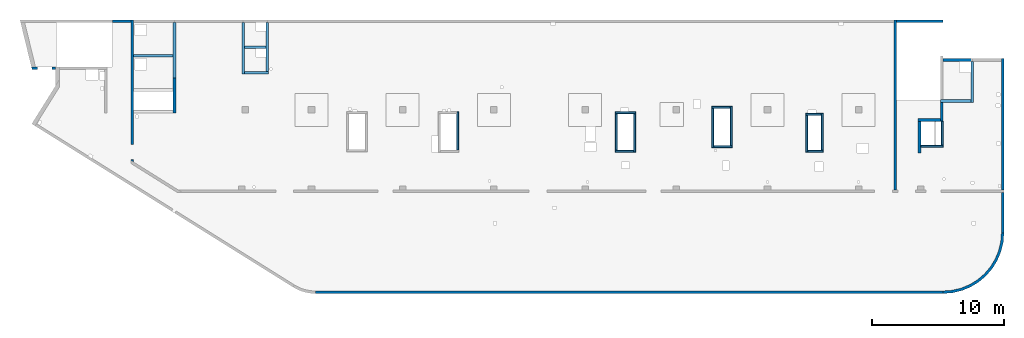
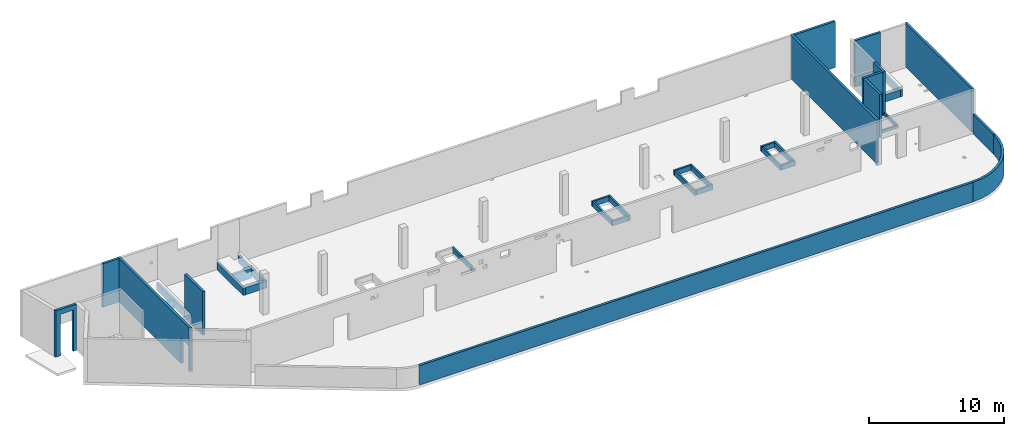
# One storey, part 3 of 6: 37 walls, 3 openings.
"""IFC4 building model written with IfcOpenShell, lengths in millimetres."""

from ifc_helpers import new_model, entity, si_unit, converted_unit, derived_unit, direction, frame, origin, place, context, subcontext, project, spatial, indexed_curve, outline, extrude, polygons, material, type_object, element, save


model = new_model("IFC4")

# Units and contexts
model_context = context("Model", 3, precision=0.01, world=origin(), true_north=direction((6.12303176911189e-17, 1.0)))
plan_context = context("Plan", 3, precision=0.01, world=origin(), true_north=direction((6.12303176911189e-17, 1.0)))
body_context = subcontext(model_context, "Body", "Model", "MODEL_VIEW")
ifc_project = project(units=[si_unit("LENGTHUNIT", "METRE", prefix="MILLI"), si_unit("AREAUNIT", "SQUARE_METRE"), si_unit("VOLUMEUNIT", "CUBIC_METRE"), converted_unit("PLANEANGLEUNIT", "DEGREE", entity("IfcRatioMeasure", 0.0174532925199433), si_unit("PLANEANGLEUNIT", "RADIAN"), dimensions=[0, 0, 0, 0, 0, 0, 0]), si_unit("MASSUNIT", "GRAM", prefix="KILO"), derived_unit("MASSDENSITYUNIT", [(si_unit("MASSUNIT", "GRAM", prefix="KILO"), 1), (si_unit("LENGTHUNIT", "METRE"), -3)]), derived_unit("MOMENTOFINERTIAUNIT", [(si_unit("LENGTHUNIT", "METRE"), 4)]), si_unit("TIMEUNIT", "SECOND"), si_unit("FREQUENCYUNIT", "HERTZ"), si_unit("THERMODYNAMICTEMPERATUREUNIT", "DEGREE_CELSIUS"), derived_unit("THERMALTRANSMITTANCEUNIT", [(si_unit("MASSUNIT", "GRAM", prefix="KILO"), 1), (si_unit("THERMODYNAMICTEMPERATUREUNIT", "KELVIN"), -1), (si_unit("TIMEUNIT", "SECOND"), -3)]), derived_unit("VOLUMETRICFLOWRATEUNIT", [(si_unit("LENGTHUNIT", "METRE"), 3), (si_unit("TIMEUNIT", "SECOND"), -1)]), derived_unit("MASSFLOWRATEUNIT", [(si_unit("MASSUNIT", "GRAM", prefix="KILO"), 1), (si_unit("TIMEUNIT", "SECOND"), -1)]), derived_unit("ROTATIONALFREQUENCYUNIT", [(si_unit("TIMEUNIT", "SECOND"), -1)]), si_unit("ELECTRICCURRENTUNIT", "AMPERE"), si_unit("ELECTRICVOLTAGEUNIT", "VOLT"), si_unit("POWERUNIT", "WATT"), si_unit("FORCEUNIT", "NEWTON", prefix="KILO"), si_unit("ILLUMINANCEUNIT", "LUX"), si_unit("LUMINOUSFLUXUNIT", "LUMEN"), si_unit("LUMINOUSINTENSITYUNIT", "CANDELA"), derived_unit("USERDEFINED", [(si_unit("MASSUNIT", "GRAM", prefix="KILO"), -1), (si_unit("LENGTHUNIT", "METRE"), -2), (si_unit("TIMEUNIT", "SECOND"), 3), (si_unit("LUMINOUSFLUXUNIT", "LUMEN"), 1)]), derived_unit("LINEARVELOCITYUNIT", [(si_unit("LENGTHUNIT", "METRE"), 1), (si_unit("TIMEUNIT", "SECOND"), -1)]), si_unit("PRESSUREUNIT", "PASCAL"), derived_unit("USERDEFINED", [(si_unit("LENGTHUNIT", "METRE"), -2), (si_unit("MASSUNIT", "GRAM", prefix="KILO"), 1), (si_unit("TIMEUNIT", "SECOND"), -2)]), derived_unit("LINEARFORCEUNIT", [(si_unit("MASSUNIT", "GRAM", prefix="KILO"), 1), (si_unit("LENGTHUNIT", "METRE"), 1), (si_unit("TIMEUNIT", "SECOND"), -2), (si_unit("LENGTHUNIT", "METRE"), -1)]), derived_unit("PLANARFORCEUNIT", [(si_unit("MASSUNIT", "GRAM", prefix="KILO"), 1), (si_unit("LENGTHUNIT", "METRE"), 1), (si_unit("TIMEUNIT", "SECOND"), -2), (si_unit("LENGTHUNIT", "METRE"), -2)])], contexts=[model_context, plan_context])

# Site, building, storey
site_placement = place(None, origin())
site = spatial("IfcSite", under=ifc_project, at=site_placement, CompositionType="ELEMENT")
building_placement = place(site_placement, origin())
building = spatial("IfcBuilding", under=site, at=building_placement, CompositionType="ELEMENT")
storey_placement = place(building_placement, frame((0.0, 0.0, 28200.0)))
storey = spatial("IfcBuildingStorey", under=building, at=storey_placement, Name="08", CompositionType="ELEMENT", Elevation=28200.0)

# Wall, opening
ifc_material = material()
wall_type_1 = type_object("IfcWallType", Name=":ADSK_ 25_200", PredefinedType="STANDARD")
wall_1_placement = place(storey_placement, frame((1805.0, 16860.0, -400.0), z_axis=(0.0, 0.0, 1.0), x_axis=(-1.0, 0.0, 0.0)))
wall_1 = element("IfcWall", 1, at=wall_1_placement, inside=storey, type_object=wall_type_1, material=ifc_material, Name=":ADSK_ 25_200", ObjectType=":ADSK_ 25_200", PredefinedType="NOTDEFINED", context=body_context, shape_type="Tessellation", body=[
    polygons([(1834.46650967482, -100.000000000001, 4200.0), (1525.68223251125, -100.000000000001, 4200.0), (2.33197173806285e-13, -100.000000000001, 4200.0), (2.33197173806285e-13, -100.000000000001, 249.999999999999), (2.33197173806285e-13, -100.000000000001, 0.0), (275.0, -100.000000000001, 0.0), (275.0, -100.000000000322, 3750.0), (1375.0, -100.000000000324, 3750.0), (1375.0, -100.000000000003, 0.0), (1525.68223251125, -100.000000000001, 0.0), (1834.46650967482, -100.000000000001, 0.0), (-6.38934712472434e-14, 100.000000000001, 4200.0), (1785.71439371649, 99.9999999999989, 4200.0), (1785.71439371649, 99.9999999999989, 0.0), (1375.0, 99.9999999999968, 0.0), (1375.0, 99.9999999999968, 3750.00000000001), (275.0, 100.000000000001, 3750.00000000001), (275.0, 100.000000000001, 0.0), (-6.38934712472434e-14, 100.000000000001, 0.0)], [[[1, 2, 3, 4, 5, 6, 7, 8, 9, 10, 11]], [[12, 13, 14, 15, 16, 17, 18, 19]], [[5, 19, 18, 6]], [[3, 2, 1, 13, 12]], [[5, 4, 3, 12, 19]], [[1, 11, 14, 13]], [[16, 8, 7, 17]], [[8, 16, 15, 9]], [[17, 7, 6, 18]], [[14, 11, 10, 9, 15]]], closed=True),
])
opening_1_placement = place(wall_1_placement, frame((1805.0, 16860.0, 400.0), z_axis=(0.0, 0.0, 1.0), x_axis=(-1.0, 0.0, 0.0)))
element("IfcOpeningElement", 2, at=opening_1_placement, cuts=wall_1, Name=":ADSK_ 25_200", PredefinedType="OPENING", context=body_context, shape_type="SweptSolid", body=[
    extrude(outline(indexed_curve([(-550.0, -3149.99999999999), (550.0, -3149.99999999999), (550.0, 3149.99999999999), (-550.0, 3149.99999999999), (-550.0, -3149.99999999999)], self_intersect=False)), frame((980.0, 16960.0, 200.0), z_axis=(0.0, -1.0, 0.0), x_axis=(-1.0, 0.0, 0.0)), (0.0, 0.0, 1.0), 200.000000000962),
])

wall_2_placement = place(storey_placement, frame((7600.0, 20500.0, -150.0), z_axis=(0.0, 0.0, 1.0), x_axis=(0.0, -1.0, 0.0)))
wall_2 = element("IfcWall", 3, at=wall_2_placement, inside=storey, type_object=wall_type_1, material=ifc_material, Name=":ADSK_ 25_200", ObjectType=":ADSK_ 25_200", PredefinedType="NOTDEFINED", context=body_context, shape_type="Tessellation", body=[
    polygons([(10624.9984109254, -99.9999999999999, 3950.0), (1979.99999999983, -100.0, 3950.0), (1019.99999999983, -99.9999999999994, 3950.0), (200.000000000037, -99.9999999999996, 3950.0), (0.0, -100.000000000001, 3950.0), (0.0, -100.000000000001, 0.0), (200.000000000037, -99.9999999999996, 0.0), (9420.00063936629, -99.9999999999996, 0.0), (9420.00063936629, -99.9999999999996, 2279.99999999804), (10550.0006393663, -99.999999999999, 2279.99999999804), (10550.0006393663, -100.0, 0.0), (10624.9984109254, -99.9999999999999, 0.0), (0.0, 100.0, 3950.0), (199.999999999998, 100.0, 3950.0), (10749.9698423134, 100.0, 3950.0), (10749.9698423134, 100.0, 0.0), (10550.0006393663, 100.0, 0.0), (10550.0006393663, 100.0, 2279.99999999804), (9420.0006393663, 100.0, 2279.99999999804), (9420.00063936629, 100.0, 0.0), (7050.00063936683, 100.0, 0.0), (6850.00063936683, 100.000000000001, 0.0), (6800.00000000003, 100.000000000001, 0.0), (5400.00000000003, 100.000000000001, 0.0), (5200.00000000003, 100.0, 0.0), (0.0, 100.0, 0.0)], [[[1, 2, 3, 4, 5, 6, 7, 8, 9, 10, 11, 12]], [[13, 14, 15, 16, 17, 18, 19, 20, 21, 22, 23, 24, 25, 26]], [[6, 26, 25, 24, 23, 22, 21, 20, 8, 7]], [[5, 4, 3, 2, 1, 15, 14, 13]], [[1, 12, 16, 15]], [[6, 5, 13, 26]], [[9, 19, 18, 10]], [[10, 18, 17, 11]], [[19, 9, 8, 20]], [[16, 12, 11, 17]]], closed=True),
])
opening_2_placement = place(wall_2_placement, frame((20500.0, -7600.0, 150.0), z_axis=(0.0, 0.0, 1.0), x_axis=(0.0, 1.0, 0.0)))
element("IfcOpeningElement", 4, at=opening_2_placement, cuts=wall_2, Name=":ADSK_ 25_200", PredefinedType="OPENING", context=body_context, shape_type="SweptSolid", body=[
    extrude(outline(indexed_curve([(-564.999999999999, -1139.99999999902), (564.999999999999, -1139.99999999902), (564.999999999999, 1139.99999999902), (-564.999999999999, 1139.99999999902), (-564.999999999999, -1139.99999999902)], self_intersect=False)), frame((7400.0, 10515.0, 990.0), z_axis=(1.0, 0.0, 0.0), x_axis=(0.0, -1.0, 0.0)), (0.0, 0.0, 1.0), 400.000000001943),
])

# Walls
wall_3_placement = place(storey_placement, frame((21464.84, -100.0, -150.0)))
element("IfcWall", 5, at=wall_3_placement, inside=storey, type_object=wall_type_1, material=ifc_material, Name=":ADSK_ 25_200", ObjectType=":ADSK_ 25_200", PredefinedType="NOTDEFINED", context=body_context, shape_type="SweptSolid", body=[
    extrude(outline(indexed_curve([(47505.1554967537, 100.0), (-3.23209822019764e-13, 100.0), (3.23209822019764e-13, -100.0), (47505.1554967537, -100.0), (47505.1554967537, 100.0)], self_intersect=False)), origin(), (0.0, 0.0, 1.0), 1770.0),
])
wall_4_placement = place(storey_placement, frame((68970.0, -100.0, -150.0)))
element("IfcWall", 6, at=wall_4_placement, inside=storey, type_object=wall_type_1, material=ifc_material, Name=":ADSK_ 25_200", ObjectType=":ADSK_ 25_200", PredefinedType="NOTDEFINED", context=body_context, shape_type="SweptSolid", body=[
    extrude(outline(indexed_curve([(4399.99918212903, 4499.99918212888), (4345.82789081698, 3811.68766389508), (4184.64789385715, 3140.32465961517), (3920.42797770043, 2502.44135458057), (3559.67411357824, 1913.74455277455), (3111.26925889869, 1388.72992323025), (2586.25462935438, 940.325068550714), (1997.55782754836, 579.571204428536), (1359.67452251375, 315.35128827184), (688.311518233829, 154.171291312031), (3.46517481375486e-11, 100.0), (0.0, -100.0), (719.598411241839, -43.3663768070019), (1421.4779213887, 125.139985012799), (2088.35592749624, 401.369899590848), (2703.81167981285, 778.521669675704), (3252.69061513598, 1247.30856699292), (3721.47751245321, 1796.18750231603), (4098.6292825381, 2411.64325463263), (4374.85919711618, 3078.52126074015), (4543.365558936, 3780.40077088701), (4599.99918212902, 4499.99918212885), (4399.99918212903, 4499.99918212888)], self_intersect=False)), origin(), (0.0, 0.0, 1.0), 1770.0),
])
wall_5_placement = place(storey_placement, frame((73470.0, 4400.0, -150.0), z_axis=(0.0, 0.0, 1.0), x_axis=(0.0, 1.0, 0.0)))
element("IfcWall", 7, at=wall_5_placement, inside=storey, type_object=wall_type_1, material=ifc_material, Name=":ADSK_ 25_200", ObjectType=":ADSK_ 25_200", PredefinedType="NOTDEFINED", context=body_context, shape_type="SweptSolid", body=[
    extrude(outline(indexed_curve([(3050.00000000025, 100.000000000001), (-2.03485596397248e-13, 100.000000000003), (2.03485596397248e-13, -100.000000000003), (3050.00000000025, -100.000000000006), (3050.00000000025, 100.000000000001)], self_intersect=False)), origin(), (0.0, 0.0, 1.0), 1770.0),
])
wall_6_placement = place(storey_placement, frame((73470.0, 7650.0, -150.0), z_axis=(0.0, 0.0, 1.0), x_axis=(0.0, 1.0, 0.0)))
element("IfcWall", 8, at=wall_6_placement, inside=storey, type_object=wall_type_1, material=ifc_material, Name=":ADSK_ 25_200", ObjectType=":ADSK_ 25_200", PredefinedType="NOTDEFINED", context=body_context, shape_type="SweptSolid", body=[
    extrude(outline(indexed_curve([(9919.99999999979, 100.000000000003), (-1.74655988596524e-13, 100.000000000003), (1.74655988596524e-13, -100.000000000003), (9919.99999999979, -100.000000000003), (9919.99999999979, 100.000000000003)], self_intersect=False)), origin(), (0.0, 0.0, 1.0), 3950.0),
])
wall_7_placement = place(storey_placement, frame((71170.0, 17370.0, -150.0), z_axis=(0.0, 0.0, 1.0), x_axis=(0.0, -1.0, 0.0)))
element("IfcWall", 9, at=wall_7_placement, inside=storey, type_object=wall_type_1, material=ifc_material, Name=":ADSK_ 25_200", ObjectType=":ADSK_ 25_200", PredefinedType="NOTDEFINED", context=body_context, shape_type="SweptSolid", body=[
    extrude(outline(indexed_curve([(3100.0, 100.000000000003), (-2.79449581754433e-13, 100.000000000003), (2.79449581754433e-13, -100.000000000003), (3100.0, -100.000000000003), (3100.0, 100.000000000003)], self_intersect=False)), origin(), (0.0, 0.0, 1.0), 650.0),
])
wall_8_placement = place(storey_placement, frame((71070.0, 14370.0, -150.0), z_axis=(0.0, 0.0, 1.0), x_axis=(-1.0, 0.0, 0.0)))
element("IfcWall", 10, at=wall_8_placement, inside=storey, type_object=wall_type_1, material=ifc_material, Name=":ADSK_ 25_200", ObjectType=":ADSK_ 25_200", PredefinedType="NOTDEFINED", context=body_context, shape_type="SweptSolid", body=[
    extrude(outline(indexed_curve([(2299.99918212887, 99.9999999999989), (-2.82487177659624e-13, 99.9999999999989), (2.82487177659624e-13, -99.9999999999989), (2299.99918212887, -99.9999999999989), (2299.99918212887, 99.9999999999989)], self_intersect=False)), origin(), (0.0, 0.0, 1.0), 650.0),
])
wall_9_placement = place(storey_placement, frame((68870.0, 14370.0, -150.0), z_axis=(0.0, 0.0, 1.0), x_axis=(0.0, -1.0, 0.0)))
element("IfcWall", 11, at=wall_9_placement, inside=storey, type_object=wall_type_1, material=ifc_material, Name=":ADSK_ 25_200", ObjectType=":ADSK_ 25_200", PredefinedType="NOTDEFINED", context=body_context, shape_type="SweptSolid", body=[
    extrude(outline(indexed_curve([(1539.99999999999, -99.9999999999946), (1539.99999999999, -49.9999999999713), (1539.99999999999, 100.000000000003), (99.9999999999989, 100.000000000003), (99.9999999999989, -99.9999999999946), (1339.99999999999, -99.9999999999946), (1539.99999999999, -99.9999999999946)], self_intersect=False)), origin(), (0.0, 0.0, 1.0), 3950.0),
])
wall_10_placement = place(storey_placement, frame((68770.0, 12930.0, -150.0), z_axis=(0.0, 0.0, 1.0), x_axis=(-1.0, 0.0, 0.0)))
element("IfcWall", 12, at=wall_10_placement, inside=storey, type_object=wall_type_1, material=ifc_material, Name=":ADSK_ 25_200", ObjectType=":ADSK_ 25_200", PredefinedType="NOTDEFINED", context=body_context, shape_type="SweptSolid", body=[
    extrude(outline(indexed_curve([(1689.99999999997, 99.9999999999989), (-3.84449868389964e-13, 99.9999999999989), (3.84449868389964e-13, -99.9999999999989), (1689.99999999997, -99.9999999999989), (1689.99999999997, 99.9999999999989)], self_intersect=False)), origin(), (0.0, 0.0, 1.0), 3950.0),
])
wall_11_placement = place(storey_placement, frame((67180.0, 12830.0, -150.0), z_axis=(0.0, 0.0, 1.0), x_axis=(0.0, -1.0, 0.0)))
element("IfcWall", 13, at=wall_11_placement, inside=storey, type_object=wall_type_1, material=ifc_material, Name=":ADSK_ 25_200", ObjectType=":ADSK_ 25_200", PredefinedType="NOTDEFINED", context=body_context, shape_type="SweptSolid", body=[
    extrude(outline(indexed_curve([(2404.99999999995, 100.000000000003), (0.0, 100.000000000003), (0.0, -100.000000000003), (2404.99999999995, -100.000000000003), (2404.99999999995, 100.000000000003)], self_intersect=False)), origin(), (0.0, 0.0, 1.0), 3950.0),
])
wall_12_placement = place(storey_placement, frame((65330.0, 7650.0, -150.0), z_axis=(0.0, 0.0, 1.0), x_axis=(0.0, 1.0, 0.0)))
element("IfcWall", 14, at=wall_12_placement, inside=storey, type_object=wall_type_1, material=ifc_material, Name=":ADSK_ 25_200", ObjectType=":ADSK_ 25_200", PredefinedType="NOTDEFINED", context=body_context, shape_type="SweptSolid", body=[
    extrude(outline(indexed_curve([(12850.000639367, 100.0), (-1.79078789910118e-13, 100.000000000003), (1.79078789910118e-13, -100.000000000003), (12850.000639367, -100.000000000006), (12850.000639367, 100.0)], self_intersect=False)), origin(), (0.0, 0.0, 1.0), 3950.0),
])

# Wall, opening
placement = place(storey_placement, frame((71170.0, 17470.0, -400.0), z_axis=(0.0, 0.0, 1.0), x_axis=(-1.0, 0.0, 0.0)))
wall_13 = element("IfcWall", 15, at=placement, inside=storey, type_object=wall_type_1, material=ifc_material, Name=":ADSK_ 25_200", ObjectType=":ADSK_ 25_200", PredefinedType="NOTDEFINED", context=body_context, shape_type="SweptSolid", body=[
    extrude(outline(indexed_curve([(2199.99918212889, 99.9999999999992), (-3.09390728867033e-13, 99.9999999999989), (3.09390728867033e-13, -99.9999999999989), (2199.99918212889, -99.9999999999986), (2199.99918212889, 99.9999999999992)], self_intersect=False)), origin(), (0.0, 0.0, 1.0), 4200.0),
])
element("IfcOpeningElement", 16, at=placement, cuts=wall_13, Name=":ADSK_ 25_200:1", PredefinedType="OPENING", context=body_context, shape_type="SweptSolid", body=[
    extrude(outline(indexed_curve([(-1009.99967285155, -120.0), (1089.99950927734, -120.0), (1089.99950927734, 80.0000000000003), (-159.999672851545, 80.0000000000008), (-1009.99967285155, 80.0000000000003), (-1009.99967285155, -120.0)], self_intersect=False)), frame((1110.0, 20.0, 900.0)), (0.0, 0.0, 1.0), 249.999999999999),
])

# Walls
wall_14_placement = place(storey_placement, frame((65430.0, 20400.0, -400.0)))
element("IfcWall", 17, at=wall_14_placement, inside=storey, type_object=wall_type_1, material=ifc_material, Name=":ADSK_ 25_200", ObjectType=":ADSK_ 25_200", PredefinedType="NOTDEFINED", context=body_context, shape_type="SweptSolid", body=[
    extrude(outline(indexed_curve([(3539.99999999996, 99.9999999999986), (-3.56989163504965e-13, 99.9999999999989), (3.56989163504965e-13, -99.9999999999989), (3539.99999999996, -99.9999999999993), (3539.99999999996, 99.9999999999986)], self_intersect=False)), origin(), (0.0, 0.0, 1.0), 4200.0),
])
wall_15_placement = place(storey_placement, frame((6100.0, 20400.0, -150.0)))
element("IfcWall", 18, at=wall_15_placement, inside=storey, type_object=wall_type_1, material=ifc_material, Name=":ADSK_ 25_200", ObjectType=":ADSK_ 25_200", PredefinedType="NOTDEFINED", context=body_context, shape_type="SweptSolid", body=[
    extrude(outline(indexed_curve([(1400.0, 99.9999999999989), (-3.09390608370965e-13, 99.9999999999989), (3.09390608370965e-13, -99.9999999999989), (1400.0, -99.9999999999989), (1400.0, 99.9999999999989)], self_intersect=False)), origin(), (0.0, 0.0, 1.0), 3950.0),
])
wall_16_placement = place(storey_placement, frame((10800.0, 13450.0, -150.0), z_axis=(0.0, 0.0, 1.0), x_axis=(0.0, 1.0, 0.0)))
element("IfcWall", 19, at=wall_16_placement, inside=storey, type_object=wall_type_1, material=ifc_material, Name=":ADSK_ 25_200", ObjectType=":ADSK_ 25_200", PredefinedType="NOTDEFINED", context=body_context, shape_type="Tessellation", body=[
    polygons([(-2.16573425859679e-12, -100.000000000002, 0.0), (2650.0, -100.000000000002, 0.0), (2650.0, -100.000000000002, 650.000000000004), (1650.0006393668, -100.000000000004, 650.000000000004), (1650.0006393668, -100.000000000004, 899.999999999999), (2650.0, -100.000000000002, 899.999999999999), (2650.0, -100.000000000002, 3950.0), (-2.16573425859679e-12, -100.000000000002, 3950.0), (2650.0, 99.9999999999981, 0.0), (1850.00063936679, 99.999999999997, 0.0), (1650.00063936679, 99.9999999999979, 0.0), (250.000639366811, 99.9999999999971, 0.0), (200.0, 99.9999999999973, 0.0), (0.0, 99.9999999999981, 0.0), (0.0, 99.9999999999981, 1200.0), (0.0, 99.9999999999981, 3950.0), (2650.0, 99.9999999999981, 3950.0), (2650.0, 99.9999999999981, 899.999999999999), (1650.0006393668, 99.9999999999979, 899.999999999999), (1650.0006393668, 99.9999999999979, 650.000000000004), (1850.00063936679, 99.999999999997, 650.0), (2650.0, 99.9999999999981, 650.000000000004)], [[[1, 2, 3, 4, 5, 6, 7, 8]], [[9, 10, 11, 12, 13, 14, 15, 16, 17, 18, 19, 20, 21, 22]], [[2, 1, 14, 13, 12, 11, 10, 9]], [[2, 9, 22, 3]], [[8, 7, 17, 16]], [[20, 4, 3, 22, 21]], [[5, 19, 18, 6]], [[4, 20, 19, 5]], [[1, 8, 16, 15, 14]], [[17, 7, 6, 18]]], closed=True),
])
wall_17_placement = place(storey_placement, frame((10800.0, 16100.0, -150.0), z_axis=(0.0, 0.0, 1.0), x_axis=(0.0, 1.0, 0.0)))
element("IfcWall", 20, at=wall_17_placement, inside=storey, type_object=wall_type_1, material=ifc_material, Name=":ADSK_ 25_200", ObjectType=":ADSK_ 25_200", PredefinedType="NOTDEFINED", context=body_context, shape_type="SweptSolid", body=[
    extrude(outline(indexed_curve([(4200.00063936683, 99.9999999999989), (-1.5469528063619e-13, 99.9999999999989), (1.5469528063619e-13, -99.9999999999989), (4200.00063936683, -99.9999999999989), (4200.00063936683, 99.9999999999989)], self_intersect=False)), origin(), (0.0, 0.0, 1.0), 650.0),
])
wall_18_placement = place(storey_placement, frame((16000.0, 16400.0, -150.0), z_axis=(0.0, 0.0, 1.0), x_axis=(0.0, 1.0, 0.0)))
element("IfcWall", 21, at=wall_18_placement, inside=storey, type_object=wall_type_1, material=ifc_material, Name=":ADSK_ 25_200", ObjectType=":ADSK_ 25_200", PredefinedType="NOTDEFINED", context=body_context, shape_type="SweptSolid", body=[
    extrude(outline(indexed_curve([(3900.00063936682, 99.9999999999989), (-1.66594915657376e-13, 99.9999999999989), (1.66594915657376e-13, -99.9999999999989), (3900.00063936682, -99.9999999999989), (3900.00063936682, 99.9999999999989)], self_intersect=False)), origin(), (0.0, 0.0, 1.0), 650.0),
])
wall_19_placement = place(storey_placement, frame((16100.0, 16500.0, -150.0)))
element("IfcWall", 22, at=wall_19_placement, inside=storey, type_object=wall_type_1, material=ifc_material, Name=":ADSK_ 25_200", ObjectType=":ADSK_ 25_200", PredefinedType="NOTDEFINED", context=body_context, shape_type="SweptSolid", body=[
    extrude(outline(indexed_curve([(1824.99999999998, 99.9999999999989), (-3.56011111002211e-13, 99.9999999999989), (3.56011111002211e-13, -99.9999999999989), (1824.99999999998, -99.9999999999989), (1824.99999999998, 99.9999999999989)], self_intersect=False)), origin(), (0.0, 0.0, 1.0), 650.0),
])
wall_20_placement = place(storey_placement, frame((17825.0, 16600.0, -150.0), z_axis=(0.0, 0.0, 1.0), x_axis=(0.0, 1.0, 0.0)))
element("IfcWall", 23, at=wall_20_placement, inside=storey, type_object=wall_type_1, material=ifc_material, Name=":ADSK_ 25_200", ObjectType=":ADSK_ 25_200", PredefinedType="NOTDEFINED", context=body_context, shape_type="SweptSolid", body=[
    extrude(outline(indexed_curve([(3700.00063936685, 99.9999999999986), (-1.66594915657375e-13, 99.9999999999989), (1.66594915657375e-13, -99.9999999999989), (3700.00063936685, -99.9999999999993), (3700.00063936685, 99.9999999999986)], self_intersect=False)), origin(), (0.0, 0.0, 1.0), 650.0),
])
wall_21_placement = place(storey_placement, frame((16100.0, 18450.0, -400.0)))
element("IfcWall", 24, at=wall_21_placement, inside=storey, type_object=wall_type_1, material=ifc_material, Name=":ADSK_ 25_200", ObjectType=":ADSK_ 25_200", PredefinedType="NOTDEFINED", context=body_context, shape_type="SweptSolid", body=[
    extrude(outline(indexed_curve([(1624.99999999999, 99.9999999999989), (-2.66551908750372e-13, 99.9999999999989), (2.66551908750372e-13, -99.9999999999989), (1624.99999999999, -99.9999999999989), (1624.99999999999, 99.9999999999989)], self_intersect=False)), origin(), (0.0, 0.0, 1.0), 900.000000000003),
])
wall_22_placement = place(storey_placement, frame((10700.0, 17800.0, -400.0), z_axis=(0.0, 0.0, 1.0), x_axis=(-1.0, 0.0, 0.0)))
element("IfcWall", 25, at=wall_22_placement, inside=storey, type_object=wall_type_1, material=ifc_material, Name=":ADSK_ 25_200", ObjectType=":ADSK_ 25_200", PredefinedType="NOTDEFINED", context=body_context, shape_type="SweptSolid", body=[
    extrude(outline(indexed_curve([(2999.99999999999, 99.9999999999989), (-2.88764567812902e-13, 99.9999999999989), (2.88764567812902e-13, -99.9999999999989), (2999.99999999999, -99.9999999999989), (2999.99999999999, 99.9999999999989)], self_intersect=False)), origin(), (0.0, 0.0, 1.0), 900.000000000003),
])
wall_type_2 = type_object("IfcWallType", Name=":ADSK_ 25_150", PredefinedType="STANDARD")
wall_23_placement = place(storey_placement, frame((32245.0, 13550.0, -150.0), z_axis=(0.0, 0.0, 1.0), x_axis=(0.0, -1.0, 0.0)))
element("IfcWall", 26, at=wall_23_placement, inside=storey, type_object=wall_type_2, material=ifc_material, Name=":ADSK_ 25_150", ObjectType=":ADSK_ 25_150", PredefinedType="NOTDEFINED", context=body_context, shape_type="SweptSolid", body=[
    extrude(outline(indexed_curve([(2925.0, 75.0000000000003), (0.0, 75.0000000000003), (0.0, -75.0000000000003), (2925.0, -75.0000000000003), (2925.0, 75.0000000000003)], self_intersect=False)), origin(), (0.0, 0.0, 1.0), 450.000000000002),
])
wall_24_placement = place(storey_placement, frame((44160.0, 13475.0, -150.0)))
element("IfcWall", 27, at=wall_24_placement, inside=storey, type_object=wall_type_2, material=ifc_material, Name=":ADSK_ 25_150", ObjectType=":ADSK_ 25_150", PredefinedType="NOTDEFINED", context=body_context, shape_type="SweptSolid", body=[
    extrude(outline(indexed_curve([(1559.99999999999, 75.0000000000013), (-2.57825506975811e-13, 75.0000000000003), (2.57825506975811e-13, -75.0000000000003), (1559.99999999999, -74.9999999999992), (1559.99999999999, 75.0000000000013)], self_intersect=False)), origin(), (0.0, 0.0, 1.0), 450.000000000002),
])
wall_25_placement = place(storey_placement, frame((45645.0, 13400.0, -150.0), z_axis=(0.0, 0.0, 1.0), x_axis=(0.0, -1.0, 0.0)))
element("IfcWall", 28, at=wall_25_placement, inside=storey, type_object=wall_type_2, material=ifc_material, Name=":ADSK_ 25_150", ObjectType=":ADSK_ 25_150", PredefinedType="NOTDEFINED", context=body_context, shape_type="SweptSolid", body=[
    extrude(outline(indexed_curve([(2924.99999999998, 75.0000000000007), (-2.34133433361817e-13, 75.0000000000003), (2.34133433361817e-13, -75.0000000000003), (2924.99999999998, -74.9999999999998), (2924.99999999998, 75.0000000000007)], self_intersect=False)), origin(), (0.0, 0.0, 1.0), 450.000000000002),
])
wall_26_placement = place(storey_placement, frame((45570.0, 10550.0, -150.0), z_axis=(0.0, 0.0, 1.0), x_axis=(-1.0, 0.0, 0.0)))
element("IfcWall", 29, at=wall_26_placement, inside=storey, type_object=wall_type_2, material=ifc_material, Name=":ADSK_ 25_150", ObjectType=":ADSK_ 25_150", PredefinedType="NOTDEFINED", context=body_context, shape_type="SweptSolid", body=[
    extrude(outline(indexed_curve([(1409.99999999998, 75.0000000000008), (-2.57825506975812e-13, 75.0000000000003), (2.57825506975812e-13, -75.0000000000003), (1409.99999999998, -74.9999999999998), (1409.99999999998, 75.0000000000008)], self_intersect=False)), origin(), (0.0, 0.0, 1.0), 450.000000000002),
])
wall_27_placement = place(storey_placement, frame((44235.0, 10625.0, -150.0), z_axis=(0.0, 0.0, 1.0), x_axis=(0.0, 1.0, 0.0)))
element("IfcWall", 30, at=wall_27_placement, inside=storey, type_object=wall_type_2, material=ifc_material, Name=":ADSK_ 25_150", ObjectType=":ADSK_ 25_150", PredefinedType="NOTDEFINED", context=body_context, shape_type="SweptSolid", body=[
    extrude(outline(indexed_curve([(2774.99999999998, 75.0000000000003), (0.0, 75.0000000000003), (0.0, -75.0000000000003), (2774.99999999998, -75.0000000000003), (2774.99999999998, 75.0000000000003)], self_intersect=False)), origin(), (0.0, 0.0, 1.0), 450.000000000002),
])
wall_28_placement = place(storey_placement, frame((51440.0, 13910.0, -150.0)))
element("IfcWall", 31, at=wall_28_placement, inside=storey, type_object=wall_type_2, material=ifc_material, Name=":ADSK_ 25_150", ObjectType=":ADSK_ 25_150", PredefinedType="NOTDEFINED", context=body_context, shape_type="SweptSolid", body=[
    extrude(outline(indexed_curve([(1410.00000000001, 75.0000000000003), (0.0, 75.0000000000003), (0.0, -75.0000000000003), (1410.00000000001, -75.0000000000003), (1410.00000000001, 75.0000000000003)], self_intersect=False)), origin(), (0.0, 0.0, 1.0), 450.000000000002),
])
wall_29_placement = place(storey_placement, frame((51515.0, 10825.0, -150.0), z_axis=(0.0, 0.0, 1.0), x_axis=(0.0, 1.0, 0.0)))
element("IfcWall", 32, at=wall_29_placement, inside=storey, type_object=wall_type_2, material=ifc_material, Name=":ADSK_ 25_150", ObjectType=":ADSK_ 25_150", PredefinedType="NOTDEFINED", context=body_context, shape_type="SweptSolid", body=[
    extrude(outline(indexed_curve([(3010.00000000002, 75.0000000000003), (0.0, 75.0000000000003), (0.0, -75.0000000000003), (3010.00000000002, -75.0000000000003), (3010.00000000002, 75.0000000000003)], self_intersect=False)), origin(), (0.0, 0.0, 1.0), 450.000000000002),
])
wall_30_placement = place(storey_placement, frame((53000.0, 10900.0, -150.0), z_axis=(0.0, 0.0, 1.0), x_axis=(-1.0, 0.0, 0.0)))
element("IfcWall", 33, at=wall_30_placement, inside=storey, type_object=wall_type_2, material=ifc_material, Name=":ADSK_ 25_150", ObjectType=":ADSK_ 25_150", PredefinedType="NOTDEFINED", context=body_context, shape_type="SweptSolid", body=[
    extrude(outline(indexed_curve([(1410.00000000001, 75.0000000000003), (0.0, 75.0000000000003), (0.0, -75.0000000000003), (1410.00000000001, -75.0000000000003), (1410.00000000001, 75.0000000000003)], self_intersect=False)), origin(), (0.0, 0.0, 1.0), 450.000000000002),
])
wall_31_placement = place(storey_placement, frame((52925.0, 13985.0, -150.0), z_axis=(0.0, 0.0, 1.0), x_axis=(0.0, -1.0, 0.0)))
element("IfcWall", 34, at=wall_31_placement, inside=storey, type_object=wall_type_2, material=ifc_material, Name=":ADSK_ 25_150", ObjectType=":ADSK_ 25_150", PredefinedType="NOTDEFINED", context=body_context, shape_type="SweptSolid", body=[
    extrude(outline(indexed_curve([(3010.00000000002, 75.0000000000003), (0.0, 75.0000000000003), (0.0, -75.0000000000003), (3010.00000000002, -75.0000000000003), (3010.00000000002, 75.0000000000003)], self_intersect=False)), origin(), (0.0, 0.0, 1.0), 450.000000000002),
])
wall_32_placement = place(storey_placement, frame((58580.0, 13370.0, -150.0)))
element("IfcWall", 35, at=wall_32_placement, inside=storey, type_object=wall_type_2, material=ifc_material, Name=":ADSK_ 25_150", ObjectType=":ADSK_ 25_150", PredefinedType="NOTDEFINED", context=body_context, shape_type="SweptSolid", body=[
    extrude(outline(indexed_curve([(1150.0, 75.0000000000003), (0.0, 75.0000000000003), (0.0, -75.0000000000003), (1150.0, -75.0000000000003), (1150.0, 75.0000000000003)], self_intersect=False)), origin(), (0.0, 0.0, 1.0), 450.000000000002),
])
wall_33_placement = place(storey_placement, frame((58655.0, 10475.0, -150.0), z_axis=(0.0, 0.0, 1.0), x_axis=(0.0, 1.0, 0.0)))
element("IfcWall", 36, at=wall_33_placement, inside=storey, type_object=wall_type_2, material=ifc_material, Name=":ADSK_ 25_150", ObjectType=":ADSK_ 25_150", PredefinedType="NOTDEFINED", context=body_context, shape_type="SweptSolid", body=[
    extrude(outline(indexed_curve([(2820.0, 75.0000000000003), (0.0, 75.0000000000003), (0.0, -75.0000000000003), (2820.0, -75.0000000000003), (2820.0, 75.0000000000003)], self_intersect=False)), origin(), (0.0, 0.0, 1.0), 450.000000000002),
])
wall_34_placement = place(storey_placement, frame((59880.0, 10550.0, -150.0), z_axis=(0.0, 0.0, 1.0), x_axis=(-1.0, 0.0, 0.0)))
element("IfcWall", 37, at=wall_34_placement, inside=storey, type_object=wall_type_2, material=ifc_material, Name=":ADSK_ 25_150", ObjectType=":ADSK_ 25_150", PredefinedType="NOTDEFINED", context=body_context, shape_type="SweptSolid", body=[
    extrude(outline(indexed_curve([(1150.0, 75.0000000000003), (0.0, 75.0000000000003), (0.0, -75.0000000000003), (1150.0, -75.0000000000003), (1150.0, 75.0000000000003)], self_intersect=False)), origin(), (0.0, 0.0, 1.0), 450.000000000002),
])
wall_35_placement = place(storey_placement, frame((59805.0, 13445.0, -150.0), z_axis=(0.0, 0.0, 1.0), x_axis=(0.0, -1.0, 0.0)))
element("IfcWall", 38, at=wall_35_placement, inside=storey, type_object=wall_type_2, material=ifc_material, Name=":ADSK_ 25_150", ObjectType=":ADSK_ 25_150", PredefinedType="NOTDEFINED", context=body_context, shape_type="SweptSolid", body=[
    extrude(outline(indexed_curve([(2820.0, 75.0000000000003), (0.0, 75.0000000000003), (0.0, -75.0000000000003), (2820.0, -75.0000000000003), (2820.0, 75.0000000000003)], self_intersect=False)), origin(), (0.0, 0.0, 1.0), 450.000000000002),
])
wall_36_placement = place(storey_placement, frame((67280.0, 10950.0, -150.0)))
element("IfcWall", 39, at=wall_36_placement, inside=storey, type_object=wall_type_2, material=ifc_material, Name=":ADSK_ 25_150", ObjectType=":ADSK_ 25_150", PredefinedType="NOTDEFINED", context=body_context, shape_type="SweptSolid", body=[
    extrude(outline(indexed_curve([(1690.0, 75.0000000000007), (-2.10948142071117e-13, 75.0000000000003), (2.10948142071117e-13, -75.0000000000003), (1690.0, -74.9999999999999), (1690.0, 75.0000000000007)], self_intersect=False)), origin(), (0.0, 0.0, 1.0), 249.999999999995),
])
wall_37_placement = place(storey_placement, frame((68895.0, 11025.0, -150.0), z_axis=(0.0, 0.0, 1.0), x_axis=(0.0, 1.0, 0.0)))
element("IfcWall", 40, at=wall_37_placement, inside=storey, type_object=wall_type_2, material=ifc_material, Name=":ADSK_ 25_150", ObjectType=":ADSK_ 25_150", PredefinedType="NOTDEFINED", context=body_context, shape_type="SweptSolid", body=[
    extrude(outline(indexed_curve([(1804.99999999999, 75.0000000000003), (0.0, 75.0000000000003), (0.0, -75.0000000000003), (1804.99999999999, -75.0000000000003), (1804.99999999999, 75.0000000000003)], self_intersect=False)), origin(), (0.0, 0.0, 1.0), 249.999999999995),
])

save(model, "model.ifc")
